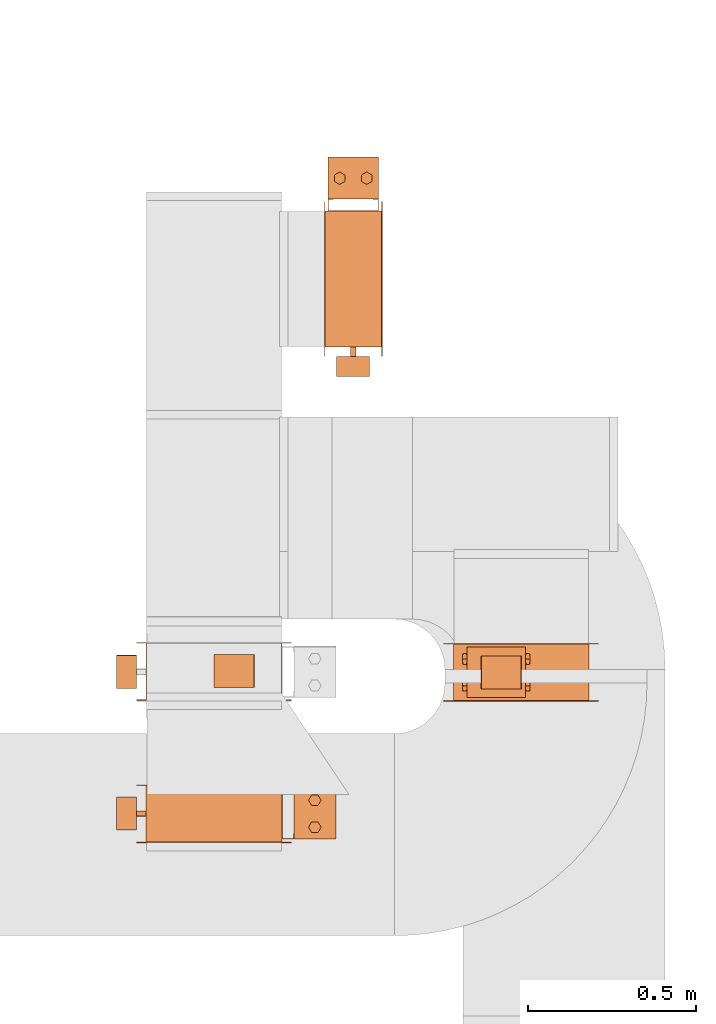
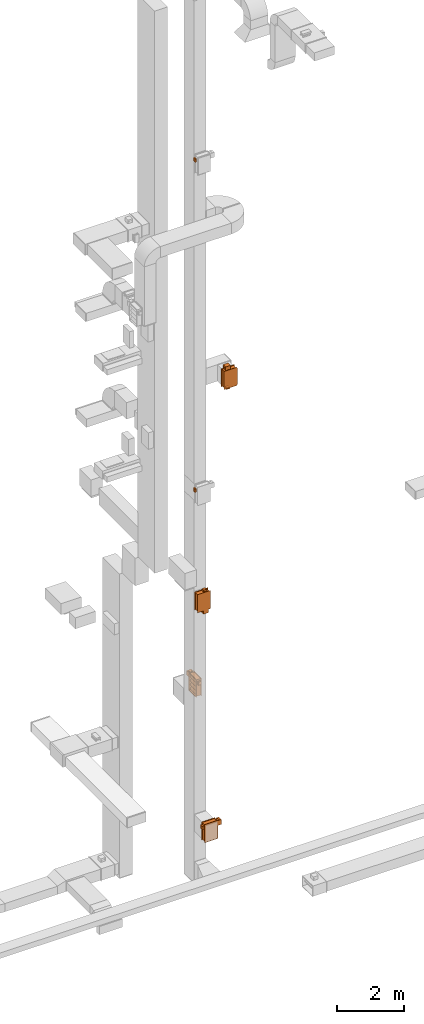
# One storey, part 26 of 29: 10 proxies.
"""IFC2X3 building model written with IfcOpenShell, lengths in millimetres."""

from ifc_helpers import new_model, entity, si_unit, converted_unit, derived_unit, direction, frame, frame_2d, origin, origin_2d_with_axis, place, context, subcontext, project, spatial, polyline, circle_curve, parameter, trimmed, segment, composite_curve, rectangle, circle, hollow_circle, outline, extrude, source, transform, mapped, material, material_list, type_object, type_shapes, element, save


model = new_model("IFC2X3")

# Units and contexts
model_context = context("Model", 3, precision=0.01, world=origin(), true_north=direction((6.12303176911189e-17, 1.0)))
body_context = subcontext(model_context, "Body", "Model", "MODEL_VIEW")
ifc_project = project(units=[si_unit("LENGTHUNIT", "METRE", prefix="MILLI"), si_unit("AREAUNIT", "SQUARE_METRE"), si_unit("VOLUMEUNIT", "CUBIC_METRE"), converted_unit("PLANEANGLEUNIT", "DEGREE", entity("IfcRatioMeasure", 0.0174532925199433), si_unit("PLANEANGLEUNIT", "RADIAN"), dimensions=[0, 0, 0, 0, 0, 0, 0]), si_unit("MASSUNIT", "GRAM", prefix="KILO"), derived_unit("MASSDENSITYUNIT", [(si_unit("MASSUNIT", "GRAM", prefix="KILO"), 1), (si_unit("LENGTHUNIT", "METRE"), -3)]), derived_unit("MOMENTOFINERTIAUNIT", [(si_unit("LENGTHUNIT", "METRE"), 4)]), si_unit("TIMEUNIT", "SECOND"), si_unit("FREQUENCYUNIT", "HERTZ"), si_unit("THERMODYNAMICTEMPERATUREUNIT", "DEGREE_CELSIUS"), derived_unit("THERMALTRANSMITTANCEUNIT", [(si_unit("MASSUNIT", "GRAM", prefix="KILO"), 1), (si_unit("THERMODYNAMICTEMPERATUREUNIT", "KELVIN"), -1), (si_unit("TIMEUNIT", "SECOND"), -3)]), derived_unit("VOLUMETRICFLOWRATEUNIT", [(si_unit("LENGTHUNIT", "METRE"), 3), (si_unit("TIMEUNIT", "SECOND"), -1)]), derived_unit("MASSFLOWRATEUNIT", [(si_unit("MASSUNIT", "GRAM", prefix="KILO"), 1), (si_unit("TIMEUNIT", "SECOND"), -1)]), derived_unit("ROTATIONALFREQUENCYUNIT", [(si_unit("TIMEUNIT", "SECOND"), -1)]), si_unit("ELECTRICCURRENTUNIT", "AMPERE"), si_unit("ELECTRICVOLTAGEUNIT", "VOLT"), si_unit("POWERUNIT", "WATT"), si_unit("FORCEUNIT", "NEWTON", prefix="KILO"), si_unit("ILLUMINANCEUNIT", "LUX"), si_unit("LUMINOUSFLUXUNIT", "LUMEN"), si_unit("LUMINOUSINTENSITYUNIT", "CANDELA"), derived_unit("USERDEFINED", [(si_unit("MASSUNIT", "GRAM", prefix="KILO"), -1), (si_unit("LENGTHUNIT", "METRE"), -2), (si_unit("TIMEUNIT", "SECOND"), 3), (si_unit("LUMINOUSFLUXUNIT", "LUMEN"), 1)]), derived_unit("LINEARVELOCITYUNIT", [(si_unit("LENGTHUNIT", "METRE"), 1), (si_unit("TIMEUNIT", "SECOND"), -1)]), si_unit("PRESSUREUNIT", "PASCAL"), derived_unit("USERDEFINED", [(si_unit("LENGTHUNIT", "METRE"), -2), (si_unit("MASSUNIT", "GRAM", prefix="KILO"), 1), (si_unit("TIMEUNIT", "SECOND"), -2)]), derived_unit("LINEARFORCEUNIT", [(si_unit("MASSUNIT", "GRAM", prefix="KILO"), 1), (si_unit("LENGTHUNIT", "METRE"), 1), (si_unit("TIMEUNIT", "SECOND"), -2), (si_unit("LENGTHUNIT", "METRE"), -1)]), derived_unit("PLANARFORCEUNIT", [(si_unit("MASSUNIT", "GRAM", prefix="KILO"), 1), (si_unit("LENGTHUNIT", "METRE"), 1), (si_unit("TIMEUNIT", "SECOND"), -2), (si_unit("LENGTHUNIT", "METRE"), -2)])], contexts=[model_context])

# Site, building, storey
site_placement = place(None, frame((0.0, -0.00077364408347762, 0.0)))
site = spatial("IfcSite", under=ifc_project, at=site_placement, CompositionType="ELEMENT")
building_placement = place(site_placement, origin())
building = spatial("IfcBuilding", under=site, at=building_placement, CompositionType="ELEMENT")
storey_placement = place(building_placement, origin())
storey = spatial("IfcBuildingStorey", under=building, at=storey_placement, CompositionType="ELEMENT", Elevation=0.0)

# Proxies
ifc_material_1 = material()
ifc_material_2 = material()
ifc_material_3 = material()
ifc_material_4 = material()
ifc_material_list_1 = material_list([ifc_material_1, ifc_material_2, ifc_material_3, ifc_material_4])
ifc_material_list_2 = material_list([ifc_material_1, ifc_material_1, ifc_material_1, ifc_material_1, ifc_material_1, ifc_material_1, ifc_material_1, ifc_material_1, ifc_material_1, ifc_material_1, ifc_material_1, ifc_material_1, ifc_material_1, ifc_material_1, ifc_material_2, ifc_material_3, ifc_material_4, ifc_material_4, ifc_material_4, ifc_material_4, ifc_material_4, ifc_material_4, ifc_material_4, ifc_material_4, ifc_material_4, ifc_material_4])
building_element_proxy_type_1 = type_object("IfcBuildingElementProxyType", PredefinedType="NOTDEFINED", material=ifc_material_list_2)
shared_shape_1 = source(origin(), body_context, "Body", "SweptSolid", [
    extrude(rectangle(XDim=1.50000000000003, YDim=150.0, at=frame_2d((0.0, 7.105427357601e-15), x_axis=(1.0, 0.0))), frame((0.0, 202.250000000103, 157.249999999651), z_axis=(0.0, 0.0, 1.0), x_axis=(0.0, -1.0, 0.0)), (0.0, 0.0, 1.0), 123.000000000001),
    extrude(outline(polyline([(-11.6740264080913, -10.5031464839717), (-10.1740264080919, -10.5031464839717), (-10.1740264080919, 4.49685351602811), (21.8480528161833, 4.49685351602811), (21.8480528161832, 6.00629296794362), (-11.6740264080913, 6.00629296794362), (-11.6740264080913, -10.5031464839717)])), frame((68.9937070320596, 224.825973592012, 157.249999999651), z_axis=(0.0, 0.0, 1.0), x_axis=(0.0, -1.0, 0.0)), (0.0, 0.0, 1.0), 25.0),
    extrude(outline(polyline([(-10.5031464839719, -11.6740264080911), (6.00629296794368, -11.6740264080911), (6.00629296794368, 21.8480528161829), (4.4968535160282, 21.8480528161829), (4.49685351602819, -10.1740264080918), (-10.5031464839718, -10.1740264080917), (-10.5031464839719, -11.6740264080911)])), frame((-68.9937070320598, 224.825973592013, 157.24999999965), z_axis=(0.0, 0.0, 1.0), x_axis=(-1.0, 0.0, 0.0)), (0.0, 0.0, 1.0), 25.0000000000005),
    extrude(outline(polyline([(-11.6740264080912, -10.503146483972), (-10.1740264080917, -10.503146483972), (-10.174026408092, 4.49685351602798), (21.8480528161832, 4.49685351602851), (21.8480528161831, 6.00629296794398), (-11.6740264080914, 6.00629296794359), (-11.6740264080912, -10.503146483972)])), frame((68.9937070320592, 224.825973592012, 255.249999999653), z_axis=(0.0, 0.0, 1.0), x_axis=(0.0, -1.0, 0.0)), (0.0, 0.0, 1.0), 25.0),
    extrude(outline(polyline([(-9.31403727272934, -16.1323857799607), (9.31403727274035, -16.1323857799607), (18.6280745454669, 0.0), (9.31403727272391, 16.132385779964), (-9.31403727273757, 16.1323857799592), (-18.6280745454642, 0.0), (-9.31403727272934, -16.1323857799607)])), frame((40.0, 299.0, 307.249999999651), z_axis=(0.0, 0.0, 1.0), x_axis=(0.866025403784569, 0.499999999999775, 0.0)), (0.0, 0.0, 1.0), 10.0),
    extrude(outline(polyline([(-9.25778653448417, -16.0349566433469), (9.25778653447845, -16.0349566433469), (18.5155730689596, 0.0), (9.25778653447818, 16.0349566433504), (-9.25778653447542, 16.0349566433453), (-18.5155730689565, 0.0), (-9.25778653448417, -16.0349566433469)])), frame((-40.0, 299.0, 307.249999999651), z_axis=(0.0, 0.0, 1.0), x_axis=(0.866025403784445, 0.499999999999988, 0.0)), (0.0, 0.0, 1.0), 10.0),
    extrude(hollow_circle(Radius=15.0, WallThickness=6.97527274236894, at=frame_2d((1.09711940467341e-28, -6.76791955811495e-14), x_axis=(1.0, 0.0))), frame((-40.0, 299.0, 305.249999999651), z_axis=(0.0, 0.0, 1.0), x_axis=(-1.0, 0.0, 0.0)), (0.0, 0.0, 1.0), 14.0),
    extrude(hollow_circle(Radius=15.0, WallThickness=7.0, at=frame_2d((1.09711940467341e-28, -6.76791955811495e-14), x_axis=(1.0, 0.0))), frame((40.0, 299.0, 305.249999999651), z_axis=(0.0, 0.0, 1.0), x_axis=(-1.0, 0.0, 0.0)), (0.0, 0.0, 1.0), 14.0),
    extrude(outline(polyline([(-10.5031464839719, -11.6740264080911), (6.00629296794375, -11.6740264080911), (6.00629296794375, 21.848052816183), (4.49685351602825, 21.848052816183), (4.49685351602798, -10.1740264080918), (-10.5031464839719, -10.1740264080917), (-10.5031464839719, -11.6740264080911)])), frame((-68.9937070320603, 224.825973592013, 255.249999999653), z_axis=(0.0, 0.0, 1.0), x_axis=(-1.0, 0.0, 0.0)), (0.0, 0.0, 1.0), 25.0),
    extrude(outline(polyline([(-9.31403727272938, -16.1323857799607), (9.31403727274159, -16.1323857799607), (18.6280745454675, 0.0), (9.31403727272273, 16.1323857799646), (-9.31403727273821, 16.1323857799588), (-18.6280745454642, 0.0), (-9.31403727272938, -16.1323857799607)])), frame((40.0, 299.0, 120.249999999651), z_axis=(0.0, 0.0, 1.0), x_axis=(0.866025403784588, 0.499999999999741, 0.0)), (0.0, 0.0, 1.0), 9.99999999999999),
    extrude(outline(polyline([(-9.25778653448427, -16.0349566433469), (9.25778653447836, -16.0349566433469), (18.5155730689595, 0.0), (9.25778653447752, 16.0349566433508), (-9.25778653447492, 16.034956643345), (-18.5155730689561, 0.0), (-9.25778653448427, -16.0349566433469)])), frame((-40.0, 299.0, 120.249999999651), z_axis=(0.0, 0.0, 1.0), x_axis=(0.866025403784446, 0.499999999999988, 0.0)), (0.0, 0.0, 1.0), 9.99999999999999),
    extrude(hollow_circle(Radius=15.0, WallThickness=6.97527274236894, at=frame_2d((1.09711940467341e-28, -6.76791955811495e-14), x_axis=(1.0, 0.0))), frame((-40.0, 299.0, 118.249999999651), z_axis=(0.0, 0.0, 1.0), x_axis=(-1.0, 0.0, 0.0)), (0.0, 0.0, 1.0), 14.0000000000001),
    extrude(hollow_circle(Radius=15.0, WallThickness=7.0, at=frame_2d((1.09711940467341e-28, -6.76791955811495e-14), x_axis=(1.0, 0.0))), frame((40.0, 299.0, 118.249999999651), z_axis=(0.0, 0.0, 1.0), x_axis=(-1.0, 0.0, 0.0)), (0.0, 0.0, 1.0), 14.0000000000001),
    extrude(rectangle(XDim=125.0, YDim=150.0, at=frame_2d((3.19744231092045e-14, 7.105427357601e-15), x_axis=(1.0, 0.0))), frame((0.0, 299.0, 132.24999999965), z_axis=(0.0, 0.0, 1.0), x_axis=(0.0, -1.0, 0.0)), (0.0, 0.0, 1.0), 173.0),
    extrude(outline(polyline([(-91.9238815542516, -374.76659402887), (-49.4974746830587, -374.76659402887), (374.76659402887, 49.4974746830578), (374.76659402887, 91.9238815542507), (91.9238815542516, 374.76659402887), (49.4974746830586, 374.76659402887), (-374.76659402887, -49.4974746830577), (-374.76659402887, -91.9238815542507), (-91.9238815542516, -374.76659402887)]), holes=[polyline([(-70.7106781186565, -353.553390593272), (-353.553390593276, -70.7106781186521), (70.7106781186561, 353.553390593279), (353.553390593276, 70.7106781186588), (-70.7106781186565, -353.553390593272)])]), frame((85.0, 0.0, 0.0), z_axis=(1.0, 0.0, 0.0), x_axis=(0.0, -0.707106781186547, -0.707106781186548)), (0.0, 0.0, 1.0), 1.50000000000001),
    extrude(rectangle(XDim=1.5, YDim=400.0, at=frame_2d((-8.43769498715119e-15, 0.0), x_axis=(1.0, 0.0))), frame((85.7499999999981, 0.0, -300.0)), (0.0, 0.0, 1.0), 600.0),
    extrude(outline(polyline([(-10.7590541572762, -14.9949864557884), (14.2409458427174, -14.9949864557884), (69.8296772996113, -6.991007520203), (69.8296772996113, 6.98098043177924), (14.2409458427207, 15.0050135442119), (-10.7590541572817, 15.005013544212), (-73.3115689850514, 6.98098043177936), (-73.3115689850514, -6.99100752020272), (-10.7590541572762, -14.9949864557884)])), frame((-1.19744613134584, -201.500000000081, 70.9214102133944), z_axis=(0.0, 1.0, 0.0), x_axis=(0.707106781186548, 0.0, 0.707106781186548)), (0.0, 0.0, 1.0), 400.0),
    extrude(outline(polyline([(-10.7590541572762, -14.9949864557884), (14.2409458427174, -14.9949864557884), (69.8296772996113, -6.991007520203), (69.8296772996113, 6.98098043177924), (14.2409458427207, 15.0050135442119), (-10.7590541572817, 15.005013544212), (-73.3115689850514, 6.98098043177937), (-73.3115689850514, -6.99100752020272), (-10.7590541572762, -14.9949864557884)])), frame((-1.19744613134584, -201.50000000008, -73.9119231199388), z_axis=(0.0, 1.0, 0.0), x_axis=(0.707106781186548, 0.0, 0.707106781186548)), (0.0, 0.0, 1.0), 400.0),
    extrude(outline(polyline([(-10.7590541572762, -14.9949864557884), (14.2409458427174, -14.9949864557884), (69.8296772996113, -6.99100752020298), (69.8296772996113, 6.98098043177923), (14.2409458427207, 15.0050135442119), (-10.7590541572817, 15.005013544212), (-73.3115689850514, 6.98098043177935), (-73.3115689850514, -6.99100752020274), (-10.7590541572762, -14.9949864557884)])), frame((-1.19744613134584, -201.50000000008, 215.754743546728), z_axis=(0.0, 1.0, 0.0), x_axis=(0.707106781186548, 0.0, 0.707106781186548)), (0.0, 0.0, 1.0), 400.0),
    extrude(outline(polyline([(-10.7590541572762, -14.9949864557884), (14.2409458427174, -14.9949864557884), (69.8296772996113, -6.99100752020298), (69.8296772996113, 6.98098043177923), (14.2409458427207, 15.0050135442119), (-10.7590541572817, 15.005013544212), (-73.3115689850514, 6.98098043177935), (-73.3115689850514, -6.99100752020274), (-10.7590541572762, -14.9949864557884)])), frame((-1.19744613134584, -201.500000000081, -218.745256453272), z_axis=(0.0, 1.0, 0.0), x_axis=(0.707106781186548, 0.0, 0.707106781186548)), (0.0, 0.0, 1.0), 400.0),
    extrude(outline(polyline([(-201.500000000085, -301.500000000003), (201.500000000085, -301.500000000003), (201.500000000085, 301.500000000003), (-201.500000000085, 301.500000000003), (-201.500000000085, -301.500000000003)]), holes=[polyline([(200.0, -300.0), (-200.0, -300.0), (-200.0, 300.0), (200.0, 300.0), (200.0, -300.0)])]), frame((-83.5000000000015, 0.0, 0.0), z_axis=(1.0, 0.0, 0.0), x_axis=(0.0, -1.0, 0.0)), (0.0, 0.0, 1.0), 167.0),
    extrude(rectangle(XDim=1.5, YDim=400.000000000054, at=origin_2d_with_axis()), frame((-0.75, 0.0, 291.0), z_axis=(0.0, 0.0, 1.0), x_axis=(-1.0, 0.0, 0.0)), (0.0, 0.0, 1.0), 8.99999999964964),
    extrude(rectangle(XDim=1.5, YDim=399.999999999998, at=origin_2d_with_axis()), frame((-0.75, 0.0, -300.0), z_axis=(0.0, 0.0, 1.0), x_axis=(-1.0, 0.0, 0.0)), (0.0, 0.0, 1.0), 9.00000000035571),
    extrude(outline(polyline([(-330.0, -229.983568238304), (-301.500000000001, -229.983568238304), (301.499999999999, -229.983568238304), (330.0, -229.983568238304), (330.0, 229.983568238304), (301.499999999999, 229.983568238304), (-301.500000000001, 229.983568238304), (-330.0, 229.983568238304), (-330.0, -229.983568238304)]), holes=[polyline([(-300.0, 200.016431761674), (300.0, 200.016431761674), (300.0, -199.983568238324), (-300.0, -199.983568238324), (-300.0, 200.016431761674)])]), frame((83.4999999999988, -0.0164317617789846, 0.0), z_axis=(1.0, 0.0, 0.0), x_axis=(0.0, 0.0, -1.0)), (0.0, 0.0, 1.0), 1.49999999999925),
    extrude(outline(polyline([(-330.0, -229.983568238491), (-301.5, -229.983568238491), (301.5, -229.983568238491), (330.0, -229.983568238491), (330.0, 229.983568238491), (301.5, 229.983568238491), (-301.5, 229.983568238492), (-330.0, 229.983568238491), (-330.0, -229.983568238491)]), holes=[polyline([(-300.0, 200.016431761505), (300.0, 200.016431761505), (300.0, -199.983568238493), (-300.0, -199.983568238493), (-300.0, 200.016431761505)])]), frame((-85.0, -0.0164317615959716, 0.0), z_axis=(1.0, 0.0, 0.0), x_axis=(0.0, 0.0, -1.0)), (0.0, 0.0, 1.0), 1.50000000000074),
    extrude(circle(Radius=8.0, at=frame_2d((0.0, -1.29243565954607e-14), x_axis=(1.0, 0.0))), frame((0.0, -230.0, 218.750000000002), z_axis=(0.0, 1.0, 0.0), x_axis=(0.0, 0.0, 1.0)), (0.0, 0.0, 1.0), 28.5),
])
type_shapes(building_element_proxy_type_1, [shared_shape_1])
proxy_1_placement = place(storey_placement, frame((32282.9809474091, 11675.2341058002, 4800.0)))
element("IfcBuildingElementProxy", 1, at=proxy_1_placement, inside=storey, type_object=building_element_proxy_type_1, material=ifc_material_list_1, context=body_context, shape_type="MappedRepresentation", body=[
    mapped(shared_shape_1, transform((0.0, 0.0, 0.0), scale=1.0)),
])
ifc_material_list_3 = material_list([ifc_material_1, ifc_material_2, ifc_material_3, ifc_material_4])
proxy_2_placement = place(storey_placement, frame((31869.8913763301, 10087.2388470346, 600.0), z_axis=(0.0, 0.0, 1.0), x_axis=(0.0, -1.0, 0.0)))
element("IfcBuildingElementProxy", 2, at=proxy_2_placement, inside=storey, type_object=building_element_proxy_type_1, material=ifc_material_list_3, context=body_context, shape_type="MappedRepresentation", body=[
    mapped(shared_shape_1, transform((0.0, 0.0, 0.0), scale=1.0)),
])
ifc_material_5 = material()
building_element_proxy_type_2 = type_object("IfcBuildingElementProxyType", PredefinedType="NOTDEFINED", material=ifc_material_5)
shared_shape_2 = source(origin(), body_context, "Body", "SweptSolid", [
    extrude(outline(composite_curve([segment(trimmed(circle_curve(frame_2d((51.6860484447997, 21.657943426465), x_axis=(1.0, 0.0)), 8.35260143157827), [parameter(360.0)], [parameter(89.9999999999998)], True, "PARAMETER"), True, "CONTINUOUS"), segment(polyline([(51.6860484447998, 30.0105448580433), (-51.629454159722, 30.0105448580518)]), True, "CONTINUOUS"), segment(trimmed(circle_curve(frame_2d((-51.629454159722, 21.6786488941551), x_axis=(1.0, 0.0)), 8.33189596389998), [parameter(90.0000000000001)], [parameter(180.0)], True, "PARAMETER"), True, "CONTINUOUS"), segment(polyline([(-59.961350123622, 21.6786488941551), (-59.9613501236187, -21.8336326480839)]), True, "CONTINUOUS"), segment(trimmed(circle_curve(frame_2d((-51.8055276297584, -21.8336326480839), x_axis=(1.0, 0.0)), 8.15582249386043), [parameter(180.0)], [parameter(270.0)], True, "PARAMETER"), True, "CONTINUOUS"), segment(polyline([(-51.8055276297584, -29.9894551419443), (51.5943338391624, -29.9894551419441)]), True, "CONTINUOUS"), segment(trimmed(circle_curve(frame_2d((51.5943338391623, -21.5451391047356), x_axis=(1.0, 0.0)), 8.44431603721898), [parameter(270.0)], [parameter(0.0)], True, "PARAMETER"), True, "CONTINUOUS"), segment(polyline([(60.0386498763813, -21.5451391047356), (60.0386498763813, 21.657943426465)]), True, "CONTINUOUS")], self_intersect=False)), frame((-49.0, 14.961350123627, 29.9894551420452), z_axis=(1.0, 0.0, 0.0), x_axis=(0.0, 1.0, 0.0)), (0.0, 0.0, 1.0), 98.0),
])
type_shapes(building_element_proxy_type_2, [shared_shape_2])
for number, where, z_axis, x_axis in (
    (3, (32282.9809474091, 11445.2341058001, 5018.74999999966), (0.0, -1.0, 0.0), (-1.0, 0.0, 0.0)),
    (4, (31639.89137633, 10087.2388470345, 818.749999999661), (-1.0, 0.0, 0.0), (0.0, 1.0, 0.0)),
    (5, (31944.1413763297, 10510.3794127018, 9030.0), (0.0, 0.0, 1.0), (0.0, 1.0, 0.0)),
    (6, (31639.89137633, 10507.4235279462, 24818.7499999997), (-1.0, 0.0, 0.0), (0.0, 1.0, 0.0)),
    (7, (31639.89137633, 10509.9993759155, 12818.7499999997), (-1.0, 0.0, 0.0), (0.0, 1.0, 0.0)),
    (8, (32707.3806775702, 10507.0551143043, 16170.0), (0.0, 0.0, -1.0), (0.0, 1.0, 0.0)),
):
    element("IfcBuildingElementProxy", number, at=place(storey_placement, frame(where, z_axis=z_axis, x_axis=x_axis)), inside=storey, type_object=building_element_proxy_type_2, material=ifc_material_5, context=body_context, shape_type="MappedRepresentation", body=[
        mapped(shared_shape_2, transform((0.0, 0.0, 0.0), scale=1.0)),
    ])
ifc_material_list_4 = material_list([ifc_material_1, ifc_material_1, ifc_material_1, ifc_material_1, ifc_material_1, ifc_material_1, ifc_material_1, ifc_material_1, ifc_material_1, ifc_material_1, ifc_material_1, ifc_material_1, ifc_material_1, ifc_material_1, ifc_material_2, ifc_material_3, ifc_material_4, ifc_material_4, ifc_material_4, ifc_material_4, ifc_material_4, ifc_material_4, ifc_material_4, ifc_material_4])
ifc_material_list_5 = material_list([ifc_material_1, ifc_material_1, ifc_material_1, ifc_material_1, ifc_material_1, ifc_material_1, ifc_material_1, ifc_material_1, ifc_material_1, ifc_material_1, ifc_material_1, ifc_material_1, ifc_material_1, ifc_material_1, ifc_material_2, ifc_material_3, ifc_material_4, ifc_material_4, ifc_material_4, ifc_material_4, ifc_material_4, ifc_material_4, ifc_material_4, ifc_material_4])
building_element_proxy_type_3 = type_object("IfcBuildingElementProxyType", PredefinedType="NOTDEFINED", material=ifc_material_list_5)
shared_shape_3 = source(origin(), body_context, "Body", "SweptSolid", [
    extrude(rectangle(XDim=1.50000000000003, YDim=150.0, at=frame_2d((-1.69309011255336e-14, 7.105427357601e-15), x_axis=(1.0, 0.0))), frame((0.0, 302.250000000102, 12.7499999996507), z_axis=(0.0, 0.0, 1.0), x_axis=(0.0, -1.0, 0.0)), (0.0, 0.0, 1.0), 123.000000000001),
    extrude(outline(polyline([(-11.6740264080913, -10.5031464839717), (-10.1740264080919, -10.5031464839717), (-10.1740264080919, 4.49685351602811), (21.8480528161833, 4.49685351602811), (21.8480528161832, 6.00629296794362), (-11.6740264080913, 6.00629296794362), (-11.6740264080913, -10.5031464839717)])), frame((68.9937070320599, 324.825973592012, 12.7499999996506), z_axis=(0.0, 0.0, 1.0), x_axis=(0.0, -1.0, 0.0)), (0.0, 0.0, 1.0), 25.0),
    extrude(outline(polyline([(-10.5031464839719, -11.6740264080912), (6.00629296794366, -11.6740264080912), (6.00629296794373, 21.8480528161829), (4.49685351602825, 21.8480528161829), (4.49685351602816, -10.1740264080918), (-10.5031464839719, -10.1740264080917), (-10.5031464839719, -11.6740264080912)])), frame((-68.9937070320596, 324.825973592012, 12.7499999996495), z_axis=(0.0, 0.0, 1.0), x_axis=(-1.0, 0.0, 0.0)), (0.0, 0.0, 1.0), 25.0000000000005),
    extrude(outline(polyline([(-11.6740264080913, -10.503146483972), (-10.1740264080918, -10.503146483972), (-10.1740264080922, 4.49685351602798), (21.8480528161831, 4.49685351602851), (21.848052816183, 6.00629296794398), (-11.6740264080915, 6.00629296794359), (-11.6740264080913, -10.503146483972)])), frame((68.9937070320594, 324.825973592011, 110.749999999652), z_axis=(0.0, 0.0, 1.0), x_axis=(0.0, -1.0, 0.0)), (0.0, 0.0, 1.0), 25.0),
    extrude(outline(polyline([(-9.31403727272929, -16.1323857799607), (9.31403727274038, -16.1323857799607), (18.6280745454669, 0.0), (9.31403727272389, 16.132385779964), (-9.3140372727376, 16.1323857799592), (-18.6280745454642, 0.0), (-9.31403727272929, -16.1323857799607)])), frame((40.0, 399.0, 162.749999999651), z_axis=(0.0, 0.0, 1.0), x_axis=(0.866025403784569, 0.499999999999774, 0.0)), (0.0, 0.0, 1.0), 9.99999999999999),
    extrude(outline(polyline([(-9.25778653448413, -16.0349566433469), (9.25778653447849, -16.0349566433469), (18.5155730689596, 0.0), (9.2577865344782, 16.0349566433505), (-9.2577865344754, 16.0349566433453), (-18.5155730689565, 0.0), (-9.25778653448413, -16.0349566433469)])), frame((-40.0, 399.0, 162.749999999651), z_axis=(0.0, 0.0, 1.0), x_axis=(0.866025403784445, 0.499999999999988, 0.0)), (0.0, 0.0, 1.0), 9.99999999999999),
    extrude(hollow_circle(Radius=15.0, WallThickness=6.97527274236894, at=frame_2d((1.09711940467341e-28, -6.76791955811495e-14), x_axis=(1.0, 0.0))), frame((-40.0, 399.0, 160.749999999651), z_axis=(0.0, 0.0, 1.0), x_axis=(-1.0, 0.0, 0.0)), (0.0, 0.0, 1.0), 14.0),
    extrude(hollow_circle(Radius=15.0, WallThickness=7.0, at=frame_2d((1.09711940467341e-28, -6.76791955811495e-14), x_axis=(1.0, 0.0))), frame((40.0, 399.0, 160.749999999651), z_axis=(0.0, 0.0, 1.0), x_axis=(-1.0, 0.0, 0.0)), (0.0, 0.0, 1.0), 14.0),
    extrude(outline(polyline([(-10.5031464839718, -11.6740264080912), (6.0062929679438, -11.6740264080912), (6.00629296794366, 21.848052816183), (4.49685351602816, 21.8480528161829), (4.49685351602802, -10.1740264080918), (-10.5031464839718, -10.1740264080918), (-10.5031464839718, -11.6740264080912)])), frame((-68.99370703206, 324.825973592012, 110.749999999652), z_axis=(0.0, 0.0, 1.0), x_axis=(-1.0, 0.0, 0.0)), (0.0, 0.0, 1.0), 25.0),
    extrude(outline(polyline([(-9.31403727272934, -16.1323857799607), (9.31403727274162, -16.1323857799607), (18.6280745454675, 0.0), (9.31403727272271, 16.1323857799646), (-9.31403727273823, 16.1323857799588), (-18.6280745454642, 0.0), (-9.31403727272934, -16.1323857799607)])), frame((40.0, 399.0, -24.2500000003491), z_axis=(0.0, 0.0, 1.0), x_axis=(0.866025403784589, 0.499999999999739, 0.0)), (0.0, 0.0, 1.0), 10.0),
    extrude(outline(polyline([(-9.25778653448419, -16.0349566433469), (9.25778653447841, -16.0349566433469), (18.5155730689595, 0.0), (9.25778653447748, 16.0349566433509), (-9.25778653447496, 16.034956643345), (-18.515573068956, 0.0), (-9.25778653448419, -16.0349566433469)])), frame((-40.0, 399.0, -24.2500000003493), z_axis=(0.0, 0.0, 1.0), x_axis=(0.866025403784447, 0.499999999999985, 0.0)), (0.0, 0.0, 1.0), 9.99999999999999),
    extrude(hollow_circle(Radius=15.0, WallThickness=6.97527274236894, at=frame_2d((9.60366808709259e-29, -6.76791955811495e-14), x_axis=(1.0, 0.0))), frame((-40.0, 399.0, -26.2500000003494), z_axis=(0.0, 0.0, 1.0), x_axis=(-1.0, 0.0, 0.0)), (0.0, 0.0, 1.0), 14.0000000000001),
    extrude(hollow_circle(Radius=15.0, WallThickness=7.0, at=frame_2d((1.09711940467341e-28, -6.76791955811495e-14), x_axis=(1.0, 0.0))), frame((40.0, 399.0, -26.2500000003491), z_axis=(0.0, 0.0, 1.0), x_axis=(-1.0, 0.0, 0.0)), (0.0, 0.0, 1.0), 14.0000000000001),
    extrude(rectangle(XDim=125.0, YDim=150.0, at=frame_2d((0.0, 7.105427357601e-15), x_axis=(1.0, 0.0))), frame((0.0, 399.0, -12.25000000035), z_axis=(0.0, 0.0, 1.0), x_axis=(0.0, -1.0, 0.0)), (0.0, 0.0, 1.0), 173.0),
    extrude(outline(polyline([(49.4974746830587, -374.76659402887), (91.9238815542517, -374.76659402887), (374.76659402887, -91.9238815542509), (374.76659402887, -49.497474683058), (-49.4974746830587, 374.76659402887), (-91.9238815542517, 374.76659402887), (-374.76659402887, 91.9238815542509), (-374.76659402887, 49.497474683058), (49.4974746830587, -374.76659402887)]), holes=[polyline([(70.7106781186538, -353.553390593272), (-353.553390593276, 70.7106781186566), (-70.710678118654, 353.553390593279), (353.553390593276, -70.7106781186499), (70.7106781186538, -353.553390593272)])]), frame((85.0, 0.0, 0.0), z_axis=(1.0, 0.0, 0.0), x_axis=(0.0, -0.707106781186548, -0.707106781186547)), (0.0, 0.0, 1.0), 1.5),
    extrude(rectangle(XDim=1.5, YDim=600.0, at=frame_2d((8.49320613838245e-15, 0.0), x_axis=(1.0, 0.0))), frame((85.7499999999981, 0.0, -200.0)), (0.0, 0.0, 1.0), 400.0),
    extrude(outline(polyline([(-10.7590541572762, -14.9949864557884), (14.2409458427174, -14.9949864557884), (69.8296772996113, -6.99100752020301), (69.8296772996113, 6.98098043177924), (14.2409458427207, 15.0050135442119), (-10.7590541572817, 15.005013544212), (-73.3115689850514, 6.98098043177936), (-73.3115689850514, -6.99100752020273), (-10.7590541572762, -14.9949864557884)])), frame((-1.19744613134584, -301.50000000008, 71.2547435467279), z_axis=(0.0, 1.0, 0.0), x_axis=(0.707106781186548, 0.0, 0.707106781186548)), (0.0, 0.0, 1.0), 600.0),
    extrude(outline(polyline([(-10.7590541572762, -14.9949864557884), (14.2409458427174, -14.9949864557884), (69.8296772996113, -6.99100752020295), (69.8296772996113, 6.98098043177929), (14.2409458427207, 15.0050135442119), (-10.7590541572817, 15.005013544212), (-73.3115689850514, 6.98098043177929), (-73.3115689850514, -6.99100752020279), (-10.7590541572762, -14.9949864557884)])), frame((-1.19744613134584, -301.50000000008, -74.245256453271), z_axis=(0.0, 1.0, 0.0), x_axis=(0.707106781186547, 0.0, 0.707106781186548)), (0.0, 0.0, 1.0), 600.0),
    extrude(outline(polyline([(-301.500000000085, -201.500000000003), (301.500000000085, -201.500000000003), (301.500000000085, 201.500000000003), (-301.500000000085, 201.500000000003), (-301.500000000085, -201.500000000003)]), holes=[polyline([(300.0, -200.0), (-300.0, -200.0), (-300.0, 200.0), (300.0, 200.0), (300.0, -200.0)])]), frame((-83.5000000000015, 0.0, 0.0), z_axis=(1.0, 0.0, 0.0), x_axis=(0.0, -1.0, 0.0)), (0.0, 0.0, 1.0), 167.0),
    extrude(rectangle(XDim=1.5, YDim=600.000000000054, at=origin_2d_with_axis()), frame((-0.75, 0.0, 146.500000000004), z_axis=(0.0, 0.0, 1.0), x_axis=(-1.0, 0.0, 0.0)), (0.0, 0.0, 1.0), 53.4999999996496),
    extrude(rectangle(XDim=1.5, YDim=599.999999999997, at=origin_2d_with_axis()), frame((-0.75, 0.0, -200.0), z_axis=(0.0, 0.0, 1.0), x_axis=(-1.0, 0.0, 0.0)), (0.0, 0.0, 1.0), 53.5000000003557),
    extrude(outline(polyline([(-230.0, -329.983568238304), (-201.500000000001, -329.983568238304), (201.499999999999, -329.983568238304), (230.0, -329.983568238304), (230.0, 329.983568238304), (201.499999999999, 329.983568238304), (-201.500000000001, 329.983568238304), (-230.0, 329.983568238304), (-230.0, -329.983568238304)]), holes=[polyline([(-200.0, 300.016431761674), (200.0, 300.016431761674), (200.0, -299.983568238323), (-200.0, -299.983568238323), (-200.0, 300.016431761674)])]), frame((83.4999999999988, -0.0164317617789762, 0.0), z_axis=(1.0, 0.0, 0.0), x_axis=(0.0, 0.0, -1.0)), (0.0, 0.0, 1.0), 1.49999999999925),
    extrude(outline(polyline([(-230.0, -329.983568238491), (-201.5, -329.983568238491), (201.5, -329.983568238491), (230.0, -329.983568238491), (230.0, 329.983568238491), (201.5, 329.983568238491), (-201.5, 329.983568238491), (-230.0, 329.983568238491), (-230.0, -329.983568238491)]), holes=[polyline([(-200.0, 300.016431761504), (200.0, 300.016431761505), (200.0, -299.983568238493), (-200.0, -299.983568238493), (-200.0, 300.016431761504)])]), frame((-85.0, -0.0164317615958193, 0.0), z_axis=(1.0, 0.0, 0.0), x_axis=(0.0, 0.0, -1.0)), (0.0, 0.0, 1.0), 1.50000000000074),
    extrude(circle(Radius=8.0, at=frame_2d((0.0, -1.29243565954607e-14), x_axis=(1.0, 0.0))), frame((0.0, -330.0, 74.2499999996541), z_axis=(0.0, 1.0, 0.0), x_axis=(0.0, 0.0, 1.0)), (0.0, 0.0, 1.0), 28.5),
])
type_shapes(building_element_proxy_type_3, [shared_shape_3])
proxy_3_placement = place(storey_placement, frame((32781.6306775699, 10507.0551143043, 16500.0), z_axis=(-1.0, 0.0, 0.0), x_axis=(0.0, -1.0, 0.0)))
element("IfcBuildingElementProxy", 9, at=proxy_3_placement, inside=storey, type_object=building_element_proxy_type_3, material=ifc_material_list_4, context=body_context, shape_type="MappedRepresentation", body=[
    mapped(shared_shape_3, transform((0.0, 0.0, 0.0), scale=1.0)),
])
ifc_material_list_6 = material_list([ifc_material_1, ifc_material_2, ifc_material_3, ifc_material_4])
proxy_4_placement = place(storey_placement, frame((31869.89137633, 10510.3794127018, 8700.0), z_axis=(1.0, 0.0, 0.0), x_axis=(0.0, -1.0, 0.0)))
element("IfcBuildingElementProxy", 10, at=proxy_4_placement, inside=storey, type_object=building_element_proxy_type_3, material=ifc_material_list_6, context=body_context, shape_type="MappedRepresentation", body=[
    mapped(shared_shape_3, transform((0.0, 0.0, 0.0), scale=1.0)),
])

save(model, "model.ifc")
